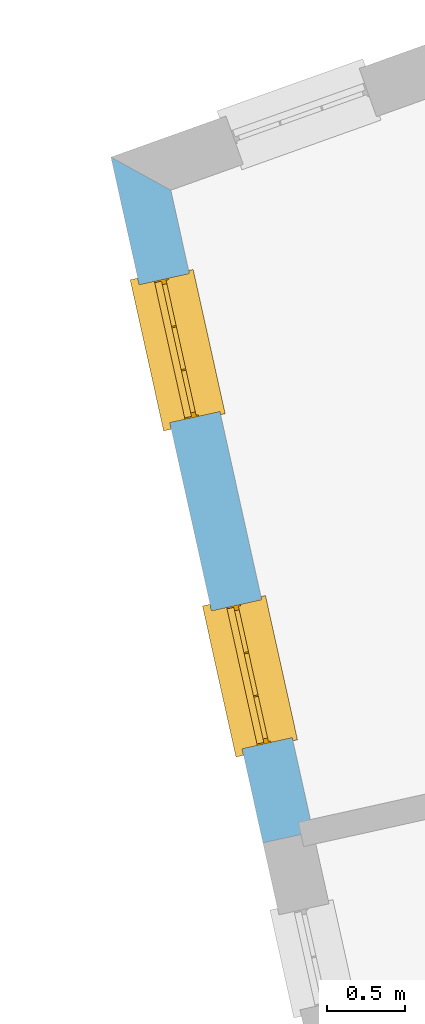
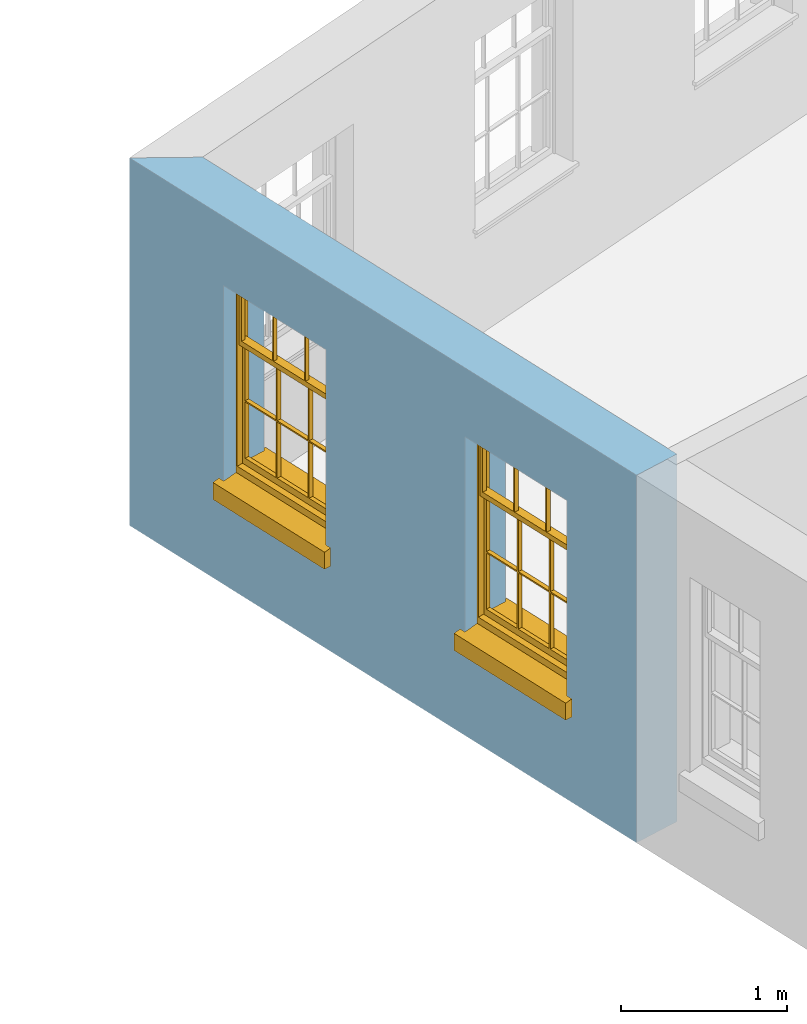
# One storey, part 3 of 11: 2 windows, 2 openings, plus 1 element that does not belong to this part.
"""IFC2X3 building model written with IfcOpenShell, lengths in metres."""

from ifc_helpers import new_model, si_unit, frame, origin, place, context, subcontext, project, spatial, polyline, outline, extrude, faceted_brep, material, layer, layer_set, layer_usage, element, fill, save


model = new_model("IFC2X3")

# Units and contexts
model_context = context("Model", 3, world=origin())
body_context = subcontext(model_context, "Body", "Model", "MODEL_VIEW")
ifc_project = project(units=[si_unit("PLANEANGLEUNIT", "RADIAN"), si_unit("MASSUNIT", "GRAM", prefix="KILO"), si_unit("FORCEUNIT", "NEWTON", prefix="KILO"), si_unit("LENGTHUNIT", "METRE")], contexts=[model_context])

# Site, building, storey
site_placement = place(None, origin())
site = spatial("IfcSite", under=ifc_project, at=site_placement, CompositionType="ELEMENT")
building_placement = place(None, origin())
building = spatial("IfcBuilding", under=site, at=building_placement, Name="Building plot-16", CompositionType="ELEMENT")
storey_placement = place(None, frame((0.0, 0.0, 9.0)))
storey = spatial("IfcBuildingStorey", under=building, at=storey_placement, Name="Floor 2", CompositionType="ELEMENT", Elevation=9.0)

# Wall, openings, windows
ifc_material = material(Name="Masonry")
ifc_layer = layer(ifc_material, 0.33, ventilated=False)
ifc_layer_set = layer_set([ifc_layer], Name="My Wall")
ifc_layer_usage = layer_usage(ifc_layer_set, "AXIS2", "NEGATIVE", 0.08)
wall_placement = place(storey_placement, origin())
wall = element("IfcWallStandardCase", 1, at=wall_placement, inside=storey, material=ifc_layer_usage, Name="exterior", context=body_context, shape_type="SweptSolid", body=[
    extrude(outline(polyline([(86.7051504212186, 37.6801216821844), (86.3199462197779, 37.892904413708), (87.2976082317312, 33.4842970421306), (87.6197813226672, 33.5557428221092), (86.7051504212186, 37.6801216821844)])), origin(), (0.0, 0.0, 1.0), 2.7),
])
opening_1_placement = place(storey_placement, frame((0.0, 0.0, 0.75)))
opening_1 = element("IfcOpeningElement", 2, at=opening_1_placement, cuts=wall, Name="Opening", ObjectType="Opening", context=body_context, shape_type="SweptSolid", body=[
    extrude(outline(polyline([(86.5016662783098, 37.0734674510234), (86.6986834291598, 36.1850507457151), (87.0208565200958, 36.2564965256937), (86.8238393692458, 37.144913231002), (86.5016662783098, 37.0734674510234)])), origin(), (0.0, 0.0, 1.0), 1.445),
])
opening_2_placement = place(storey_placement, frame((0.0, 0.0, 0.75)))
opening_2 = element("IfcOpeningElement", 3, at=opening_2_placement, cuts=wall, Name="Opening", ObjectType="Opening", context=body_context, shape_type="SweptSolid", body=[
    extrude(outline(polyline([(86.9666218636407, 34.9768260801977), (87.1636390144908, 34.0884093748893), (87.4858121054268, 34.1598551548679), (87.2887949545767, 35.0482718601763), (86.9666218636407, 34.9768260801977)])), origin(), (0.0, 0.0, 1.0), 1.445),
])
window_1_placement = place(storey_placement, frame((86.7457368017461, 37.1275930419163, 0.75), z_axis=(0.0, 0.0, 1.0), x_axis=(0.197017150850044, -0.888416705308344, 0.0)))
window_1 = element("IfcWindow", 4, at=window_1_placement, inside=storey, Name="living outside window", OverallHeight=1.445, OverallWidth=0.91, context=body_context, shape_type="Brep", held_by="IfcProductRepresentation", body=[
    faceted_brep([(0.876875, -0.105, 0.999097), (0.876875, -0.105, 1.411875), (0.9, -0.105, 1.435), (0.033125, -0.105, 1.411875), (0.033125, -0.105, 0.999097), (0.01, -0.105, 1.435), (0.033125, -0.135, 1.411875), (0.01, -0.135, 1.435), (0.033125, -0.135, 0.999097), (0.876875, -0.135, 1.411875), (0.876875, -0.135, 0.999097), (0.9, -0.135, 1.435), (0.033125, -0.105, 0.960972), (0.01, -0.105, 0.960972), (0.033125, -0.105, 0.548195), (0.876875, -0.105, 0.960972), (0.876875, -0.105, 0.548195), (0.9, -0.105, 0.960972), (0.876875, -0.105, 0.538195), (0.876875, -0.105, 0.125417), (0.9, -0.105, 0.077167), (0.033125, -0.105, 0.125417), (0.033125, -0.105, 0.538195), (0.01, -0.105, 0.077167), (0.9, -0.135, 0.960972), (0.01, -0.135, 0.960972), (-0.0425, -0.25, 0.01), (-0.0425, -0.3, 0.001667), (0.0, -0.25, 0.01), (0.9525, -0.25, 0.01), (0.91, -0.25, 0.01), (0.9525, -0.3, 0.001667), (-0.02, 0.08, 0.077167), (0.0, 0.08, 0.077167), (-0.02, 0.11, 0.077167), (0.0, -0.06, 0.077167), (0.01, -0.06, 0.077167), (0.91, -0.06, 0.077167), (0.91, 0.08, 0.077167), (0.9, -0.06, 0.077167), (0.93, 0.08, 0.077167), (0.93, 0.11, 0.077167), (0.01, -0.105, 0.999097), (0.01, -0.075, 0.999097), (0.9, -0.105, 0.999097), (0.9, -0.075, 0.999097), (0.876875, -0.075, 0.125417), (0.876875, -0.075, 0.538195), (0.9, -0.075, 0.077167), (0.876875, -0.075, 0.548195), (0.876875, -0.075, 0.960972), (0.033125, -0.075, 0.125417), (0.01, -0.075, 0.077167), (0.033125, -0.075, 0.538195), (0.033125, -0.075, 0.960972), (0.033125, -0.075, 0.548195), (-0.02, 0.08, 0.052167), (-0.02, 0.11, 0.052167), (0.93, 0.11, 0.052167), (0.93, 0.08, 0.052167), (0.91, 0.08, 0.052167), (0.0, 0.08, 0.052167), (0.91, -0.15, 0.026667), (0.0, -0.15, 0.026667), (-0.0425, -0.3, -0.123333), (0.9525, -0.3, -0.123333), (-0.0425, -0.25, -0.123333), (0.9525, -0.25, -0.123333), (0.01, -0.06, 1.435), (0.9, -0.06, 1.435), (0.0, -0.06, 1.445), (0.91, -0.06, 1.445), (0.01, -0.15, 0.077167), (0.9, -0.15, 0.077167), (0.592292, -0.105, 0.125417), (0.592292, -0.075, 0.125417), (0.317708, -0.075, 0.125417), (0.317708, -0.105, 0.125417), (0.592292, -0.105, 0.548195), (0.317708, -0.105, 0.548195), (0.317708, -0.105, 0.538195), (0.592292, -0.105, 0.538195), (0.592292, -0.075, 0.548195), (0.317708, -0.075, 0.548195), (0.602292, -0.075, 0.548195), (0.602292, -0.105, 0.548195), (0.317708, -0.075, 0.538195), (0.307708, -0.075, 0.125417), (0.307708, -0.075, 0.538195), (0.602292, -0.075, 0.538195), (0.602292, -0.075, 0.125417), (0.592292, -0.075, 0.538195), (0.307708, -0.075, 0.548195), (0.317708, -0.075, 0.960972), (0.307708, -0.075, 0.960972), (0.602292, -0.075, 0.960972), (0.592292, -0.075, 0.960972), (0.307708, -0.105, 0.538195), (0.307708, -0.105, 0.125417), (0.307708, -0.105, 0.548195), (0.307708, -0.105, 0.960972), (0.592292, -0.105, 0.960972), (0.317708, -0.105, 0.960972), (0.602292, -0.105, 0.960972), (0.602292, -0.105, 0.538195), (0.602292, -0.105, 0.125417), (0.317708, -0.135, 1.411875), (0.307708, -0.135, 1.411875), (0.307708, -0.135, 0.999097), (0.317708, -0.135, 0.999097), (0.602292, -0.135, 1.411875), (0.592292, -0.135, 1.411875), (0.592292, -0.135, 0.999097), (0.602292, -0.135, 0.999097), (0.317708, -0.105, 0.999097), (0.307708, -0.105, 0.999097), (0.307708, -0.105, 1.411875), (0.317708, -0.105, 1.411875), (0.602292, -0.105, 0.999097), (0.592292, -0.105, 0.999097), (0.592292, -0.105, 1.411875), (0.602292, -0.105, 1.411875), (0.91, -0.15, 1.445), (0.9, -0.15, 1.435), (0.01, -0.15, 1.435), (0.0, -0.15, 1.445), (0.91, -0.25, 0.0), (0.0, -0.25, 0.0), (0.91, 0.08, 0.0), (0.0, 0.08, 0.0)], [[[0, 1, 2]], [[3, 4, 5]], [[6, 7, 8]], [[9, 10, 11]], [[12, 13, 14]], [[15, 16, 17]], [[18, 19, 20]], [[21, 22, 23]], [[24, 15, 17]], [[13, 12, 25]], [[26, 27, 28]], [[29, 30, 31]], [[32, 33, 34]], [[35, 36, 33]], [[37, 38, 39]], [[40, 41, 38]], [[42, 4, 43]], [[44, 45, 0]], [[46, 47, 48]], [[49, 50, 45]], [[51, 52, 53]], [[54, 55, 43]], [[38, 33, 36, 39]], [[41, 34, 33, 38]], [[56, 32, 34, 57]], [[57, 34, 41, 58]], [[58, 41, 40, 59]], [[57, 58, 60, 61]], [[52, 48, 39, 36]], [[62, 63, 28, 30]], [[27, 31, 30, 28]], [[27, 64, 65, 31]], [[66, 67, 65, 64]], [[2, 5, 68, 69]], [[68, 70, 71, 69]], [[20, 23, 72, 73]], [[73, 72, 63, 62]], [[74, 75, 76, 77]], [[78, 79, 80, 81]], [[78, 82, 83, 79]], [[16, 49, 84, 85]], [[86, 76, 87, 88]], [[89, 90, 75, 91]], [[92, 88, 53, 55]], [[82, 91, 86, 83]], [[93, 83, 92, 94]], [[95, 84, 82, 96]], [[89, 84, 49, 47]], [[97, 88, 87, 98]], [[22, 53, 88, 97]], [[81, 91, 75, 74]], [[80, 86, 91, 81]], [[77, 76, 86, 80]], [[99, 92, 55, 14]], [[100, 94, 92, 99]], [[101, 96, 82, 78]], [[79, 83, 93, 102]], [[85, 84, 95, 103]], [[104, 89, 47, 18]], [[105, 90, 89, 104]], [[104, 18, 16, 85]], [[80, 97, 98, 77]], [[104, 81, 74, 105]], [[103, 101, 78, 85]], [[99, 14, 22, 97]], [[102, 100, 99, 79]], [[106, 107, 108, 109]], [[110, 111, 112, 113]], [[114, 115, 116, 117]], [[118, 119, 120, 121]], [[107, 116, 115, 108]], [[111, 120, 119, 112]], [[109, 114, 117, 106]], [[113, 118, 121, 110]], [[85, 78, 81, 104]], [[84, 89, 91, 82]], [[83, 86, 88, 92]], [[79, 99, 97, 80]], [[109, 112, 119, 114]], [[102, 93, 96, 101]], [[106, 117, 120, 111]], [[98, 87, 51, 21]], [[6, 3, 116, 107]], [[110, 121, 1, 9]], [[19, 46, 90, 105]], [[26, 66, 64, 27]], [[29, 31, 65, 67]], [[25, 24, 112, 109]], [[11, 7, 106, 111]], [[75, 48, 52, 76]], [[43, 45, 96, 93]], [[45, 43, 114, 119]], [[5, 2, 120, 117]], [[24, 25, 102, 101]], [[42, 5, 4]], [[2, 44, 0]], [[49, 45, 48, 47]], [[52, 43, 55, 53]], [[14, 13, 23, 22]], [[20, 17, 16, 18]], [[24, 11, 10]], [[25, 8, 7]], [[8, 4, 3, 6]], [[9, 1, 0, 10]], [[15, 50, 49, 16]], [[18, 47, 46, 19]], [[21, 51, 53, 22]], [[14, 55, 54, 12]], [[44, 2, 69, 45]], [[68, 5, 42, 43]], [[36, 35, 70, 68]], [[39, 69, 71, 37]], [[62, 122, 123, 73]], [[63, 72, 124, 125]], [[8, 108, 115, 4]], [[113, 10, 0, 118]], [[94, 100, 12, 54]], [[17, 20, 73, 24]], [[72, 23, 13, 25]], [[52, 36, 68, 43]], [[69, 39, 48, 45]], [[11, 24, 73, 123]], [[7, 124, 72, 25]], [[23, 77, 98]], [[98, 21, 23]], [[105, 74, 20]], [[20, 19, 105]], [[20, 74, 77, 23]], [[113, 112, 24]], [[24, 10, 113]], [[25, 109, 108]], [[108, 8, 25]], [[110, 9, 11]], [[11, 111, 110]], [[7, 6, 107]], [[107, 106, 7]], [[5, 117, 116]], [[116, 3, 5]], [[121, 120, 2]], [[2, 1, 121]], [[11, 123, 124, 7]], [[122, 125, 124, 123]], [[43, 93, 94]], [[94, 54, 43]], [[96, 45, 95]], [[50, 95, 45]], [[15, 103, 95, 50]], [[48, 75, 90]], [[90, 46, 48]], [[87, 76, 52]], [[52, 51, 87]], [[103, 15, 24]], [[24, 101, 103]], [[100, 102, 25]], [[25, 12, 100]], [[115, 114, 43]], [[43, 4, 115]], [[118, 0, 45]], [[45, 119, 118]], [[71, 70, 125, 122]], [[70, 35, 63, 125]], [[122, 62, 37, 71]], [[126, 67, 66, 127]], [[60, 58, 59]], [[38, 60, 59, 40]], [[61, 56, 57]], [[32, 56, 61, 33]], [[61, 60, 128, 129]], [[62, 60, 38, 37]], [[126, 128, 60, 62]], [[33, 61, 63, 35]], [[61, 129, 127, 63]], [[128, 126, 127, 129]], [[28, 127, 66, 26]], [[63, 127, 28]], [[29, 67, 126, 30]], [[30, 126, 62]]]),
])
fill(opening_1, window_1)
window_2_placement = place(storey_placement, frame((87.2106923870771, 35.0309516710905, 0.75), z_axis=(0.0, 0.0, 1.0), x_axis=(0.197017150850044, -0.888416705308344, 0.0)))
window_2 = element("IfcWindow", 5, at=window_2_placement, inside=storey, Name="living outside window", OverallHeight=1.445, OverallWidth=0.91, context=body_context, shape_type="Brep", held_by="IfcProductRepresentation", body=[
    faceted_brep([(0.876875, -0.105, 0.999097), (0.876875, -0.105, 1.411875), (0.9, -0.105, 1.435), (0.033125, -0.105, 1.411875), (0.033125, -0.105, 0.999097), (0.01, -0.105, 1.435), (0.033125, -0.135, 1.411875), (0.01, -0.135, 1.435), (0.033125, -0.135, 0.999097), (0.876875, -0.135, 1.411875), (0.876875, -0.135, 0.999097), (0.9, -0.135, 1.435), (0.033125, -0.105, 0.960972), (0.01, -0.105, 0.960972), (0.033125, -0.105, 0.548195), (0.876875, -0.105, 0.960972), (0.876875, -0.105, 0.548195), (0.9, -0.105, 0.960972), (0.876875, -0.105, 0.538195), (0.876875, -0.105, 0.125417), (0.9, -0.105, 0.077167), (0.033125, -0.105, 0.125417), (0.033125, -0.105, 0.538195), (0.01, -0.105, 0.077167), (0.9, -0.135, 0.960972), (0.01, -0.135, 0.960972), (-0.0425, -0.25, 0.01), (-0.0425, -0.3, 0.001667), (0.0, -0.25, 0.01), (0.9525, -0.25, 0.01), (0.91, -0.25, 0.01), (0.9525, -0.3, 0.001667), (-0.02, 0.08, 0.077167), (0.0, 0.08, 0.077167), (-0.02, 0.11, 0.077167), (0.0, -0.06, 0.077167), (0.01, -0.06, 0.077167), (0.91, -0.06, 0.077167), (0.91, 0.08, 0.077167), (0.9, -0.06, 0.077167), (0.93, 0.08, 0.077167), (0.93, 0.11, 0.077167), (0.01, -0.105, 0.999097), (0.01, -0.075, 0.999097), (0.9, -0.105, 0.999097), (0.9, -0.075, 0.999097), (0.876875, -0.075, 0.125417), (0.876875, -0.075, 0.538195), (0.9, -0.075, 0.077167), (0.876875, -0.075, 0.548195), (0.876875, -0.075, 0.960972), (0.033125, -0.075, 0.125417), (0.01, -0.075, 0.077167), (0.033125, -0.075, 0.538195), (0.033125, -0.075, 0.960972), (0.033125, -0.075, 0.548195), (-0.02, 0.08, 0.052167), (-0.02, 0.11, 0.052167), (0.93, 0.11, 0.052167), (0.93, 0.08, 0.052167), (0.91, 0.08, 0.052167), (0.0, 0.08, 0.052167), (0.91, -0.15, 0.026667), (0.0, -0.15, 0.026667), (-0.0425, -0.3, -0.123333), (0.9525, -0.3, -0.123333), (-0.0425, -0.25, -0.123333), (0.9525, -0.25, -0.123333), (0.01, -0.06, 1.435), (0.9, -0.06, 1.435), (0.0, -0.06, 1.445), (0.91, -0.06, 1.445), (0.01, -0.15, 0.077167), (0.9, -0.15, 0.077167), (0.592292, -0.105, 0.125417), (0.592292, -0.075, 0.125417), (0.317708, -0.075, 0.125417), (0.317708, -0.105, 0.125417), (0.592292, -0.105, 0.548195), (0.317708, -0.105, 0.548195), (0.317708, -0.105, 0.538195), (0.592292, -0.105, 0.538195), (0.592292, -0.075, 0.548195), (0.317708, -0.075, 0.548195), (0.602292, -0.075, 0.548195), (0.602292, -0.105, 0.548195), (0.317708, -0.075, 0.538195), (0.307708, -0.075, 0.125417), (0.307708, -0.075, 0.538195), (0.602292, -0.075, 0.538195), (0.602292, -0.075, 0.125417), (0.592292, -0.075, 0.538195), (0.307708, -0.075, 0.548195), (0.317708, -0.075, 0.960972), (0.307708, -0.075, 0.960972), (0.602292, -0.075, 0.960972), (0.592292, -0.075, 0.960972), (0.307708, -0.105, 0.538195), (0.307708, -0.105, 0.125417), (0.307708, -0.105, 0.548195), (0.307708, -0.105, 0.960972), (0.592292, -0.105, 0.960972), (0.317708, -0.105, 0.960972), (0.602292, -0.105, 0.960972), (0.602292, -0.105, 0.538195), (0.602292, -0.105, 0.125417), (0.317708, -0.135, 1.411875), (0.307708, -0.135, 1.411875), (0.307708, -0.135, 0.999097), (0.317708, -0.135, 0.999097), (0.602292, -0.135, 1.411875), (0.592292, -0.135, 1.411875), (0.592292, -0.135, 0.999097), (0.602292, -0.135, 0.999097), (0.317708, -0.105, 0.999097), (0.307708, -0.105, 0.999097), (0.307708, -0.105, 1.411875), (0.317708, -0.105, 1.411875), (0.602292, -0.105, 0.999097), (0.592292, -0.105, 0.999097), (0.592292, -0.105, 1.411875), (0.602292, -0.105, 1.411875), (0.91, -0.15, 1.445), (0.9, -0.15, 1.435), (0.01, -0.15, 1.435), (0.0, -0.15, 1.445), (0.91, -0.25, 0.0), (0.0, -0.25, 0.0), (0.91, 0.08, 0.0), (0.0, 0.08, 0.0)], [[[0, 1, 2]], [[3, 4, 5]], [[6, 7, 8]], [[9, 10, 11]], [[12, 13, 14]], [[15, 16, 17]], [[18, 19, 20]], [[21, 22, 23]], [[24, 15, 17]], [[13, 12, 25]], [[26, 27, 28]], [[29, 30, 31]], [[32, 33, 34]], [[35, 36, 33]], [[37, 38, 39]], [[40, 41, 38]], [[42, 4, 43]], [[44, 45, 0]], [[46, 47, 48]], [[49, 50, 45]], [[51, 52, 53]], [[54, 55, 43]], [[38, 33, 36, 39]], [[41, 34, 33, 38]], [[56, 32, 34, 57]], [[57, 34, 41, 58]], [[58, 41, 40, 59]], [[57, 58, 60, 61]], [[52, 48, 39, 36]], [[62, 63, 28, 30]], [[27, 31, 30, 28]], [[27, 64, 65, 31]], [[66, 67, 65, 64]], [[2, 5, 68, 69]], [[68, 70, 71, 69]], [[20, 23, 72, 73]], [[73, 72, 63, 62]], [[74, 75, 76, 77]], [[78, 79, 80, 81]], [[78, 82, 83, 79]], [[16, 49, 84, 85]], [[86, 76, 87, 88]], [[89, 90, 75, 91]], [[92, 88, 53, 55]], [[82, 91, 86, 83]], [[93, 83, 92, 94]], [[95, 84, 82, 96]], [[89, 84, 49, 47]], [[97, 88, 87, 98]], [[22, 53, 88, 97]], [[81, 91, 75, 74]], [[80, 86, 91, 81]], [[77, 76, 86, 80]], [[99, 92, 55, 14]], [[100, 94, 92, 99]], [[101, 96, 82, 78]], [[79, 83, 93, 102]], [[85, 84, 95, 103]], [[104, 89, 47, 18]], [[105, 90, 89, 104]], [[104, 18, 16, 85]], [[80, 97, 98, 77]], [[104, 81, 74, 105]], [[103, 101, 78, 85]], [[99, 14, 22, 97]], [[102, 100, 99, 79]], [[106, 107, 108, 109]], [[110, 111, 112, 113]], [[114, 115, 116, 117]], [[118, 119, 120, 121]], [[107, 116, 115, 108]], [[111, 120, 119, 112]], [[109, 114, 117, 106]], [[113, 118, 121, 110]], [[85, 78, 81, 104]], [[84, 89, 91, 82]], [[83, 86, 88, 92]], [[79, 99, 97, 80]], [[109, 112, 119, 114]], [[102, 93, 96, 101]], [[106, 117, 120, 111]], [[98, 87, 51, 21]], [[6, 3, 116, 107]], [[110, 121, 1, 9]], [[19, 46, 90, 105]], [[26, 66, 64, 27]], [[29, 31, 65, 67]], [[25, 24, 112, 109]], [[11, 7, 106, 111]], [[75, 48, 52, 76]], [[43, 45, 96, 93]], [[45, 43, 114, 119]], [[5, 2, 120, 117]], [[24, 25, 102, 101]], [[42, 5, 4]], [[2, 44, 0]], [[49, 45, 48, 47]], [[52, 43, 55, 53]], [[14, 13, 23, 22]], [[20, 17, 16, 18]], [[24, 11, 10]], [[25, 8, 7]], [[8, 4, 3, 6]], [[9, 1, 0, 10]], [[15, 50, 49, 16]], [[18, 47, 46, 19]], [[21, 51, 53, 22]], [[14, 55, 54, 12]], [[44, 2, 69, 45]], [[68, 5, 42, 43]], [[36, 35, 70, 68]], [[39, 69, 71, 37]], [[62, 122, 123, 73]], [[63, 72, 124, 125]], [[8, 108, 115, 4]], [[113, 10, 0, 118]], [[94, 100, 12, 54]], [[17, 20, 73, 24]], [[72, 23, 13, 25]], [[52, 36, 68, 43]], [[69, 39, 48, 45]], [[11, 24, 73, 123]], [[7, 124, 72, 25]], [[23, 77, 98]], [[98, 21, 23]], [[105, 74, 20]], [[20, 19, 105]], [[20, 74, 77, 23]], [[113, 112, 24]], [[24, 10, 113]], [[25, 109, 108]], [[108, 8, 25]], [[110, 9, 11]], [[11, 111, 110]], [[7, 6, 107]], [[107, 106, 7]], [[5, 117, 116]], [[116, 3, 5]], [[121, 120, 2]], [[2, 1, 121]], [[11, 123, 124, 7]], [[122, 125, 124, 123]], [[43, 93, 94]], [[94, 54, 43]], [[96, 45, 95]], [[50, 95, 45]], [[15, 103, 95, 50]], [[48, 75, 90]], [[90, 46, 48]], [[87, 76, 52]], [[52, 51, 87]], [[103, 15, 24]], [[24, 101, 103]], [[100, 102, 25]], [[25, 12, 100]], [[115, 114, 43]], [[43, 4, 115]], [[118, 0, 45]], [[45, 119, 118]], [[71, 70, 125, 122]], [[70, 35, 63, 125]], [[122, 62, 37, 71]], [[126, 67, 66, 127]], [[60, 58, 59]], [[38, 60, 59, 40]], [[61, 56, 57]], [[32, 56, 61, 33]], [[61, 60, 128, 129]], [[62, 60, 38, 37]], [[126, 128, 60, 62]], [[33, 61, 63, 35]], [[61, 129, 127, 63]], [[128, 126, 127, 129]], [[28, 127, 66, 26]], [[63, 127, 28]], [[29, 67, 126, 30]], [[30, 126, 62]]]),
])
fill(opening_2, window_2)

save(model, "model.ifc")
